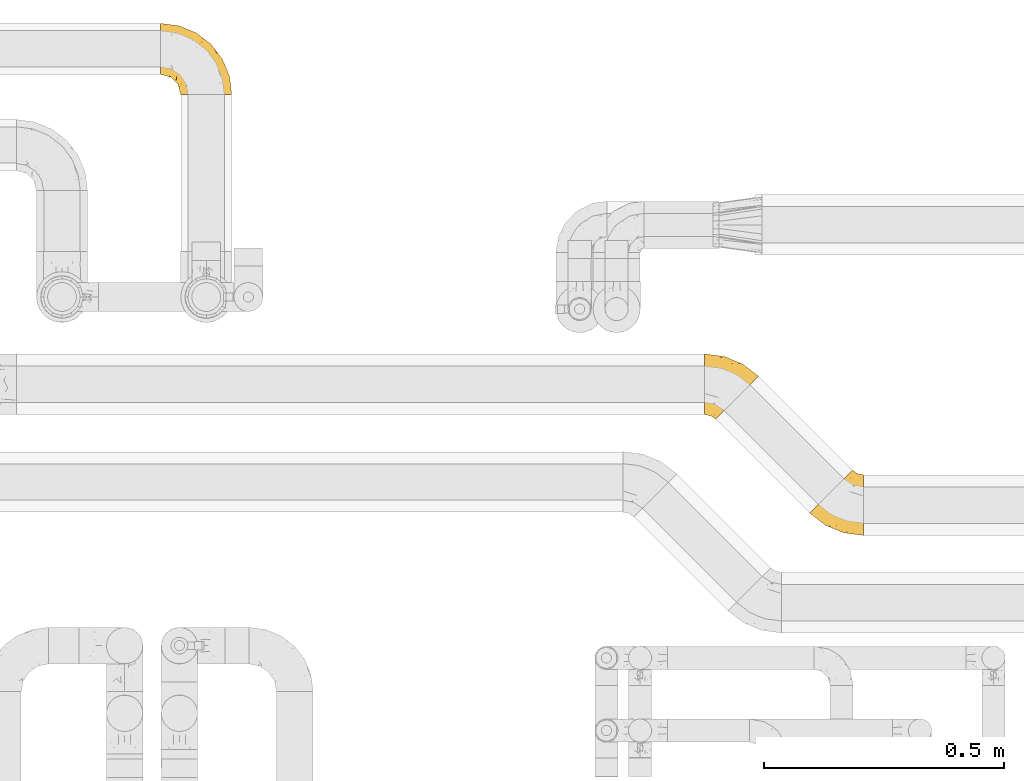
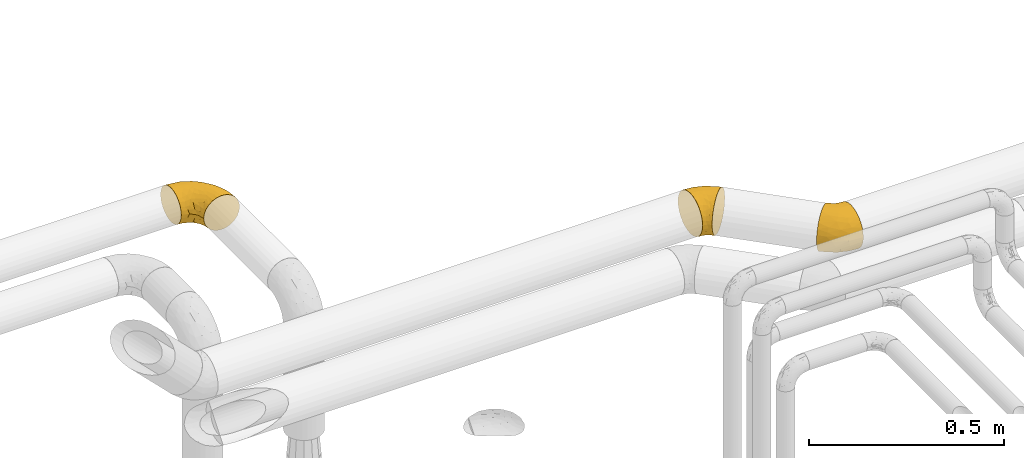
# One storey, part 412 of 827: 3 coverings.
"""IFC2X3 building model written with IfcOpenShell, lengths in millimetres."""

from ifc_helpers import new_model, entity, si_unit, converted_unit, derived_unit, direction, frame, origin, place, context, subcontext, project, spatial, faceted_brep, element, save


model = new_model("IFC2X3")

# Units and contexts
model_context = context("Model", 3, precision=0.01, world=origin(), true_north=direction((6.12303176911189e-17, 1.0)))
body_context = subcontext(model_context, "Body", "Model", "MODEL_VIEW")
ifc_project = project(units=[si_unit("LENGTHUNIT", "METRE", prefix="MILLI"), si_unit("AREAUNIT", "SQUARE_METRE"), si_unit("VOLUMEUNIT", "CUBIC_METRE"), converted_unit("PLANEANGLEUNIT", "DEGREE", entity("IfcRatioMeasure", 0.0174532925199433), si_unit("PLANEANGLEUNIT", "RADIAN"), dimensions=[0, 0, 0, 0, 0, 0, 0]), si_unit("MASSUNIT", "GRAM", prefix="KILO"), derived_unit("MASSDENSITYUNIT", [(si_unit("MASSUNIT", "GRAM", prefix="KILO"), 1), (si_unit("LENGTHUNIT", "METRE"), -3)]), derived_unit("MOMENTOFINERTIAUNIT", [(si_unit("LENGTHUNIT", "METRE"), 4)]), si_unit("TIMEUNIT", "SECOND"), si_unit("FREQUENCYUNIT", "HERTZ"), si_unit("THERMODYNAMICTEMPERATUREUNIT", "DEGREE_CELSIUS"), derived_unit("THERMALTRANSMITTANCEUNIT", [(si_unit("MASSUNIT", "GRAM", prefix="KILO"), 1), (si_unit("THERMODYNAMICTEMPERATUREUNIT", "KELVIN"), -1), (si_unit("TIMEUNIT", "SECOND"), -3)]), derived_unit("VOLUMETRICFLOWRATEUNIT", [(si_unit("LENGTHUNIT", "METRE"), 3), (si_unit("TIMEUNIT", "SECOND"), -1)]), derived_unit("MASSFLOWRATEUNIT", [(si_unit("MASSUNIT", "GRAM", prefix="KILO"), 1), (si_unit("TIMEUNIT", "SECOND"), -1)]), derived_unit("ROTATIONALFREQUENCYUNIT", [(si_unit("TIMEUNIT", "SECOND"), -1)]), si_unit("ELECTRICCURRENTUNIT", "AMPERE"), si_unit("ELECTRICVOLTAGEUNIT", "VOLT"), si_unit("POWERUNIT", "WATT"), si_unit("FORCEUNIT", "NEWTON", prefix="KILO"), si_unit("ILLUMINANCEUNIT", "LUX"), si_unit("LUMINOUSFLUXUNIT", "LUMEN"), si_unit("LUMINOUSINTENSITYUNIT", "CANDELA"), derived_unit("USERDEFINED", [(si_unit("MASSUNIT", "GRAM", prefix="KILO"), -1), (si_unit("LENGTHUNIT", "METRE"), -2), (si_unit("TIMEUNIT", "SECOND"), 3), (si_unit("LUMINOUSFLUXUNIT", "LUMEN"), 1)]), derived_unit("LINEARVELOCITYUNIT", [(si_unit("LENGTHUNIT", "METRE"), 1), (si_unit("TIMEUNIT", "SECOND"), -1)]), si_unit("PRESSUREUNIT", "PASCAL"), derived_unit("USERDEFINED", [(si_unit("LENGTHUNIT", "METRE"), -2), (si_unit("MASSUNIT", "GRAM", prefix="KILO"), 1), (si_unit("TIMEUNIT", "SECOND"), -2)]), derived_unit("LINEARFORCEUNIT", [(si_unit("MASSUNIT", "GRAM", prefix="KILO"), 1), (si_unit("LENGTHUNIT", "METRE"), 1), (si_unit("TIMEUNIT", "SECOND"), -2), (si_unit("LENGTHUNIT", "METRE"), -1)]), derived_unit("PLANARFORCEUNIT", [(si_unit("MASSUNIT", "GRAM", prefix="KILO"), 1), (si_unit("LENGTHUNIT", "METRE"), 1), (si_unit("TIMEUNIT", "SECOND"), -2), (si_unit("LENGTHUNIT", "METRE"), -2)])], contexts=[model_context])

# Site, building, storey
site_placement = place(None, origin())
site = spatial("IfcSite", under=ifc_project, at=site_placement, CompositionType="ELEMENT")
building_placement = place(site_placement, origin())
building = spatial("IfcBuilding", under=site, at=building_placement, CompositionType="ELEMENT")
storey_placement = place(building_placement, frame((0.0, 0.0, 28200.0)))
storey = spatial("IfcBuildingStorey", under=building, at=storey_placement, Name="08", CompositionType="ELEMENT", Elevation=28200.0)

# Coverings
covering_1_placement = place(storey_placement, frame((48061.03, 18493.86, 2935.35)))
element("IfcCovering", 1, at=covering_1_placement, inside=storey, Name=":ADSK_", ObjectType=":ADSK_", PredefinedType="INSULATION", context=body_context, shape_type="Brep", body=[
    faceted_brep([(113.35, 127.7, 64.65), (113.35, 126.11, 78.67), (113.35, 121.45, 92.0), (113.35, 113.94, 103.95), (113.35, 103.96, 113.94), (113.35, 92.0, 121.45), (113.35, 78.68, 126.11), (113.35, 64.65, 127.7), (113.35, 50.62, 126.11), (113.35, 37.29, 121.45), (113.35, 25.34, 113.94), (113.35, 15.35, 103.96), (113.35, 7.84, 92.0), (113.35, 3.18, 78.68), (113.35, 1.6, 64.65), (113.35, 3.18, 50.62), (113.35, 7.84, 37.29), (113.35, 15.35, 25.34), (113.35, 25.33, 15.35), (113.35, 37.29, 7.84), (113.35, 50.61, 3.18), (113.35, 64.65, 1.6), (113.35, 78.67, 3.18), (113.35, 92.0, 7.84), (113.35, 103.95, 15.35), (113.35, 113.94, 25.33), (113.35, 121.45, 37.29), (113.35, 126.11, 50.61), (90.76, 137.05, 64.65), (89.24, 135.53, 48.33), (84.79, 131.08, 33.12), (77.7, 124.0, 20.06), (68.47, 114.76, 10.04), (57.72, 104.01, 3.74), (46.18, 92.47, 1.6), (34.64, 80.93, 3.74), (23.89, 70.18, 10.04), (14.65, 60.95, 20.06), (7.57, 53.86, 33.12), (3.11, 49.41, 48.33), (1.6, 47.89, 64.65), (3.11, 49.41, 80.96), (7.57, 53.86, 96.17), (14.65, 60.95, 109.23), (23.89, 70.18, 119.25), (34.64, 80.93, 125.55), (46.18, 92.47, 127.7), (57.72, 104.01, 125.55), (68.47, 114.76, 119.25), (77.7, 124.0, 109.23), (84.79, 131.08, 96.17), (89.24, 135.53, 80.96), (82.25, 22.45, 108.1), (34.33, 22.77, 64.65), (21.83, 33.18, 80.19), (32.11, 38.64, 102.05), (72.45, 6.98, 64.65), (42.98, 20.62, 81.27), (69.69, 54.22, 124.73), (45.61, 59.86, 122.26), (78.83, 8.74, 84.6), (55.06, 37.39, 113.02), (65.85, 77.37, 127.7), (56.15, 84.82, 127.7), (86.72, 13.12, 97.32), (56.96, 21.15, 96.3), (86.58, 32.48, 117.12), (26.66, 34.19, 90.52), (100.89, 66.29, 127.7), (88.77, 67.88, 127.7), (77.31, 72.63, 127.7), (65.07, 43.92, 119.88), (102.7, 95.22, 120.26), (100.29, 80.66, 125.9), (69.96, 95.96, 125.09), (81.48, 107.27, 117.94), (100.72, 107.42, 112.32), (90.26, 93.57, 122.53), (96.84, 118.48, 102.2), (86.87, 121.19, 105.16), (91.1, 111.65, 111.58), (106.05, 117.49, 99.98), (95.88, 131.99, 74.42), (101.77, 125.2, 87.77), (104.32, 127.93, 75.98), (87.42, 80.56, 126.59), (79.05, 88.58, 125.61), (92.68, 128.43, 90.37), (101.13, 130.13, 64.65), (101.77, 125.19, 41.51), (100.72, 107.41, 16.97), (97.53, 130.44, 52.07), (81.48, 107.27, 11.35), (69.96, 95.96, 4.2), (93.01, 126.18, 35.35), (96.84, 118.48, 27.09), (56.15, 84.82, 1.6), (87.42, 80.56, 2.7), (88.77, 67.88, 1.6), (77.31, 72.63, 1.6), (102.7, 95.22, 9.03), (90.26, 93.56, 6.76), (77.09, 85.62, 2.86), (79.18, 96.8, 6.13), (86.87, 121.19, 24.13), (91.09, 111.65, 17.7), (100.29, 80.66, 3.39), (106.05, 117.49, 29.31), (100.89, 66.29, 1.6), (65.85, 77.37, 1.6), (69.69, 54.22, 4.56), (45.61, 59.86, 7.03), (82.25, 22.44, 21.19), (55.07, 37.39, 16.27), (86.58, 32.48, 12.17), (86.72, 13.12, 31.97), (56.96, 21.15, 33.0), (32.11, 38.63, 27.24), (21.84, 33.18, 49.11), (26.66, 34.19, 38.77), (78.83, 8.73, 44.69), (42.98, 20.62, 48.02), (65.07, 43.91, 9.41)], [[[0, 1, 2, 3, 4, 5, 6, 7, 8, 9, 10, 11, 12, 13, 14, 15, 16, 17, 18, 19, 20, 21, 22, 23, 24, 25, 26, 27]], [[28, 29, 30, 31, 32, 33, 34, 35, 36, 37, 38, 39, 40, 41, 42, 43, 44, 45, 46, 47, 48, 49, 50, 51]], [[52, 11, 10]], [[40, 53, 54]], [[42, 55, 43]], [[53, 56, 57]], [[9, 8, 58]], [[45, 59, 58]], [[56, 13, 60]], [[61, 44, 43]], [[45, 62, 63, 46]], [[62, 45, 58]], [[59, 45, 44]], [[64, 52, 65]], [[55, 61, 43]], [[61, 65, 52]], [[60, 57, 56]], [[60, 65, 57]], [[52, 10, 66]], [[64, 12, 11]], [[64, 60, 12]], [[13, 56, 14]], [[61, 55, 65]], [[67, 55, 42]], [[54, 67, 41]], [[61, 52, 66]], [[66, 10, 9]], [[8, 7, 68, 69]], [[58, 69, 70, 62]], [[58, 8, 69]], [[60, 64, 65]], [[52, 64, 11]], [[58, 59, 71]], [[54, 57, 67]], [[58, 66, 9]], [[60, 13, 12]], [[41, 67, 42]], [[65, 55, 67]], [[65, 67, 57]], [[40, 54, 41]], [[53, 57, 54]], [[44, 61, 59]], [[58, 71, 66]], [[59, 61, 71]], [[61, 66, 71]], [[72, 73, 5]], [[62, 74, 63]], [[48, 75, 49]], [[63, 74, 47]], [[75, 48, 74]], [[72, 76, 77]], [[78, 79, 80]], [[81, 3, 2]], [[82, 28, 51]], [[83, 84, 82]], [[73, 77, 85]], [[86, 62, 70]], [[83, 87, 78]], [[50, 87, 51]], [[86, 75, 74]], [[68, 73, 69]], [[5, 4, 72]], [[73, 6, 5]], [[74, 48, 47]], [[73, 68, 6]], [[80, 77, 76]], [[69, 85, 70]], [[81, 76, 3]], [[88, 84, 0]], [[84, 83, 1]], [[1, 83, 2]], [[3, 76, 4]], [[50, 49, 79]], [[83, 78, 81]], [[80, 76, 78]], [[73, 72, 77]], [[76, 72, 4]], [[85, 86, 70]], [[68, 7, 6]], [[73, 85, 69]], [[86, 85, 77]], [[75, 86, 77]], [[86, 74, 62]], [[47, 46, 63]], [[83, 81, 2]], [[76, 81, 78]], [[75, 79, 49]], [[87, 79, 78]], [[79, 75, 80]], [[77, 80, 75]], [[0, 84, 1]], [[82, 84, 88]], [[28, 82, 88]], [[82, 51, 87]], [[87, 50, 79]], [[82, 87, 83]], [[27, 26, 89]], [[25, 24, 90]], [[88, 91, 28]], [[32, 92, 93]], [[94, 89, 95]], [[94, 29, 91]], [[93, 96, 33]], [[97, 98, 99]], [[24, 23, 100]], [[101, 102, 103]], [[104, 95, 105]], [[93, 33, 32]], [[100, 90, 24]], [[102, 97, 99]], [[91, 27, 89]], [[97, 106, 98]], [[26, 107, 89]], [[93, 92, 103]], [[90, 95, 107]], [[31, 92, 32]], [[31, 30, 104]], [[107, 26, 25]], [[23, 22, 106]], [[101, 97, 102]], [[89, 94, 91]], [[31, 104, 92]], [[98, 106, 108]], [[106, 22, 108]], [[100, 106, 101]], [[101, 92, 105]], [[106, 100, 23]], [[27, 88, 0]], [[90, 100, 101]], [[22, 21, 108]], [[93, 102, 109]], [[106, 97, 101]], [[109, 102, 99]], [[102, 93, 103]], [[96, 93, 109]], [[96, 34, 33]], [[101, 103, 92]], [[90, 107, 25]], [[89, 107, 95]], [[94, 104, 30]], [[95, 90, 105]], [[101, 105, 90]], [[92, 104, 105]], [[104, 94, 95]], [[29, 94, 30]], [[28, 91, 29]], [[27, 91, 88]], [[35, 110, 111]], [[112, 113, 114]], [[35, 34, 96, 109]], [[112, 114, 18]], [[112, 115, 116]], [[117, 113, 116]], [[39, 118, 40]], [[116, 119, 117]], [[120, 121, 116]], [[113, 117, 37]], [[36, 113, 37]], [[38, 117, 119]], [[119, 116, 121]], [[20, 19, 110]], [[110, 109, 99, 98]], [[122, 111, 110]], [[20, 98, 108, 21]], [[37, 117, 38]], [[112, 18, 17]], [[39, 119, 118]], [[116, 113, 112]], [[110, 35, 109]], [[119, 39, 38]], [[114, 19, 18]], [[121, 120, 56]], [[115, 17, 16]], [[15, 14, 56]], [[15, 56, 120]], [[110, 19, 114]], [[115, 120, 116]], [[121, 56, 53]], [[15, 120, 16]], [[115, 112, 17]], [[20, 110, 98]], [[120, 115, 16]], [[35, 111, 36]], [[119, 121, 118]], [[121, 53, 118]], [[40, 118, 53]], [[122, 110, 114]], [[113, 36, 111]], [[114, 113, 122]], [[113, 111, 122]]]),
])
covering_2_placement = place(storey_placement, frame((47842.77, 18735.82, 2935.35)))
element("IfcCovering", 2, at=covering_2_placement, inside=storey, Name=":ADSK_", ObjectType=":ADSK_", PredefinedType="INSULATION", context=body_context, shape_type="Brep", body=[
    faceted_brep([(1.6, 10.95, 64.65), (1.6, 12.53, 78.67), (1.6, 17.2, 92.0), (1.6, 24.71, 103.95), (1.6, 34.69, 113.94), (1.6, 46.64, 121.45), (1.6, 59.97, 126.11), (1.6, 74.0, 127.7), (1.6, 88.03, 126.11), (1.6, 101.36, 121.45), (1.6, 113.31, 113.94), (1.6, 123.3, 103.96), (1.6, 130.81, 92.0), (1.6, 135.47, 78.68), (1.6, 137.05, 64.65), (1.6, 135.47, 50.62), (1.6, 130.81, 37.29), (1.6, 123.3, 25.34), (1.6, 113.32, 15.35), (1.6, 101.36, 7.84), (1.6, 88.04, 3.18), (1.6, 74.0, 1.6), (1.6, 59.97, 3.18), (1.6, 46.65, 7.84), (1.6, 34.69, 15.35), (1.6, 24.71, 25.33), (1.6, 17.2, 37.29), (1.6, 12.53, 50.61), (24.19, 1.6, 64.65), (25.71, 3.11, 48.33), (30.16, 7.57, 33.12), (37.25, 14.65, 20.06), (46.48, 23.89, 10.04), (57.23, 34.64, 3.74), (68.77, 46.18, 1.6), (80.31, 57.72, 3.74), (91.06, 68.47, 10.04), (100.3, 77.7, 20.06), (107.38, 84.79, 33.12), (111.83, 89.24, 48.33), (113.35, 90.76, 64.65), (111.83, 89.24, 80.96), (107.38, 84.79, 96.17), (100.3, 77.7, 109.23), (91.06, 68.47, 119.25), (80.31, 57.72, 125.55), (68.77, 46.18, 127.7), (57.23, 34.64, 125.55), (46.48, 23.89, 119.25), (37.25, 14.65, 109.23), (30.16, 7.57, 96.17), (25.71, 3.11, 80.96), (32.7, 116.2, 108.1), (80.62, 115.88, 64.65), (93.11, 105.47, 80.19), (82.84, 100.01, 102.05), (42.5, 131.67, 64.65), (71.97, 118.02, 81.27), (45.26, 84.43, 124.73), (69.34, 78.79, 122.26), (36.12, 129.91, 84.6), (59.89, 101.26, 113.02), (49.1, 61.28, 127.7), (58.8, 53.83, 127.7), (28.22, 125.53, 97.32), (57.99, 117.49, 96.3), (28.36, 106.16, 117.12), (88.29, 104.46, 90.52), (14.06, 72.36, 127.7), (26.18, 70.77, 127.7), (37.64, 66.02, 127.7), (49.88, 94.73, 119.88), (12.25, 43.42, 120.26), (14.66, 57.99, 125.9), (44.99, 42.69, 125.09), (33.47, 31.37, 117.94), (14.23, 31.23, 112.32), (24.69, 45.08, 122.53), (18.1, 20.17, 102.2), (28.08, 17.46, 105.16), (23.85, 27.0, 111.58), (8.9, 21.15, 99.98), (19.06, 6.66, 74.42), (13.18, 13.45, 87.77), (10.63, 10.72, 75.98), (27.52, 58.08, 126.59), (35.9, 50.06, 125.61), (22.27, 10.21, 90.37), (13.82, 8.52, 64.65), (13.18, 13.45, 41.51), (14.23, 31.24, 16.97), (17.42, 8.21, 52.07), (33.46, 31.38, 11.35), (44.99, 42.69, 4.2), (21.94, 12.47, 35.35), (18.11, 20.17, 27.09), (58.8, 53.83, 1.6), (27.53, 58.09, 2.7), (26.18, 70.77, 1.6), (37.64, 66.02, 1.6), (12.25, 43.43, 9.03), (24.69, 45.08, 6.76), (37.86, 53.03, 2.86), (35.77, 41.85, 6.13), (28.08, 17.46, 24.13), (23.85, 27.0, 17.7), (14.66, 57.99, 3.39), (8.9, 21.16, 29.31), (14.06, 72.36, 1.6), (49.1, 61.28, 1.6), (45.26, 84.43, 4.56), (69.34, 78.79, 7.03), (32.7, 116.21, 21.19), (59.88, 101.26, 16.27), (28.36, 106.17, 12.17), (28.23, 125.53, 31.97), (57.99, 117.5, 33.0), (82.84, 100.01, 27.24), (93.11, 105.47, 49.11), (88.29, 104.46, 38.77), (36.12, 129.91, 44.69), (71.97, 118.03, 48.02), (49.88, 94.73, 9.41)], [[[0, 1, 2, 3, 4, 5, 6, 7, 8, 9, 10, 11, 12, 13, 14, 15, 16, 17, 18, 19, 20, 21, 22, 23, 24, 25, 26, 27]], [[28, 29, 30, 31, 32, 33, 34, 35, 36, 37, 38, 39, 40, 41, 42, 43, 44, 45, 46, 47, 48, 49, 50, 51]], [[52, 11, 10]], [[40, 53, 54]], [[42, 55, 43]], [[53, 56, 57]], [[9, 8, 58]], [[45, 59, 58]], [[56, 13, 60]], [[61, 44, 43]], [[45, 62, 63, 46]], [[62, 45, 58]], [[59, 45, 44]], [[64, 52, 65]], [[55, 61, 43]], [[61, 65, 52]], [[60, 57, 56]], [[60, 65, 57]], [[52, 10, 66]], [[64, 12, 11]], [[64, 60, 12]], [[13, 56, 14]], [[61, 55, 65]], [[67, 55, 42]], [[54, 67, 41]], [[61, 52, 66]], [[66, 10, 9]], [[8, 7, 68, 69]], [[58, 69, 70, 62]], [[58, 8, 69]], [[60, 64, 65]], [[52, 64, 11]], [[58, 59, 71]], [[54, 57, 67]], [[58, 66, 9]], [[60, 13, 12]], [[41, 67, 42]], [[65, 55, 67]], [[65, 67, 57]], [[40, 54, 41]], [[53, 57, 54]], [[44, 61, 59]], [[58, 71, 66]], [[59, 61, 71]], [[61, 66, 71]], [[72, 73, 5]], [[62, 74, 63]], [[48, 75, 49]], [[63, 74, 47]], [[75, 48, 74]], [[72, 76, 77]], [[78, 79, 80]], [[81, 3, 2]], [[82, 28, 51]], [[83, 84, 82]], [[73, 77, 85]], [[86, 62, 70]], [[83, 87, 78]], [[50, 87, 51]], [[86, 75, 74]], [[68, 73, 69]], [[5, 4, 72]], [[73, 6, 5]], [[74, 48, 47]], [[73, 68, 6]], [[80, 77, 76]], [[69, 85, 70]], [[81, 76, 3]], [[88, 84, 0]], [[84, 83, 1]], [[1, 83, 2]], [[3, 76, 4]], [[50, 49, 79]], [[83, 78, 81]], [[80, 76, 78]], [[73, 72, 77]], [[76, 72, 4]], [[85, 86, 70]], [[68, 7, 6]], [[73, 85, 69]], [[86, 85, 77]], [[75, 86, 77]], [[86, 74, 62]], [[47, 46, 63]], [[83, 81, 2]], [[76, 81, 78]], [[75, 79, 49]], [[87, 79, 78]], [[79, 75, 80]], [[77, 80, 75]], [[0, 84, 1]], [[82, 84, 88]], [[28, 82, 88]], [[82, 51, 87]], [[87, 50, 79]], [[82, 87, 83]], [[27, 26, 89]], [[25, 24, 90]], [[88, 91, 28]], [[32, 92, 93]], [[94, 89, 95]], [[94, 29, 91]], [[93, 96, 33]], [[97, 98, 99]], [[24, 23, 100]], [[101, 102, 103]], [[104, 95, 105]], [[93, 33, 32]], [[100, 90, 24]], [[102, 97, 99]], [[91, 27, 89]], [[97, 106, 98]], [[26, 107, 89]], [[93, 92, 103]], [[90, 95, 107]], [[31, 92, 32]], [[31, 30, 104]], [[107, 26, 25]], [[23, 22, 106]], [[101, 97, 102]], [[89, 94, 91]], [[31, 104, 92]], [[98, 106, 108]], [[106, 22, 108]], [[100, 106, 101]], [[101, 92, 105]], [[106, 100, 23]], [[27, 88, 0]], [[90, 100, 101]], [[22, 21, 108]], [[93, 102, 109]], [[106, 97, 101]], [[109, 102, 99]], [[102, 93, 103]], [[96, 93, 109]], [[96, 34, 33]], [[101, 103, 92]], [[90, 107, 25]], [[89, 107, 95]], [[94, 104, 30]], [[95, 90, 105]], [[101, 105, 90]], [[92, 104, 105]], [[104, 94, 95]], [[29, 94, 30]], [[28, 91, 29]], [[27, 91, 88]], [[35, 110, 111]], [[112, 113, 114]], [[35, 34, 96, 109]], [[112, 114, 18]], [[112, 115, 116]], [[117, 113, 116]], [[39, 118, 40]], [[116, 119, 117]], [[120, 121, 116]], [[113, 117, 37]], [[36, 113, 37]], [[38, 117, 119]], [[119, 116, 121]], [[20, 19, 110]], [[110, 109, 99, 98]], [[122, 111, 110]], [[20, 98, 108, 21]], [[37, 117, 38]], [[112, 18, 17]], [[39, 119, 118]], [[116, 113, 112]], [[110, 35, 109]], [[119, 39, 38]], [[114, 19, 18]], [[121, 120, 56]], [[115, 17, 16]], [[15, 14, 56]], [[15, 56, 120]], [[110, 19, 114]], [[115, 120, 116]], [[121, 56, 53]], [[15, 120, 16]], [[115, 112, 17]], [[20, 110, 98]], [[120, 115, 16]], [[35, 111, 36]], [[119, 121, 118]], [[121, 53, 118]], [[40, 118, 53]], [[122, 110, 114]], [[113, 36, 111]], [[114, 113, 122]], [[113, 111, 122]]]),
])
covering_3_placement = place(storey_placement, frame((46711.22, 19410.64, 2945.35)))
element("IfcCovering", 3, at=covering_3_placement, inside=storey, Name=":ADSK_", ObjectType=":ADSK_", PredefinedType="INSULATION", context=body_context, shape_type="Brep", body=[
    faceted_brep([(1.6, 148.32, 66.44), (1.6, 149.65, 54.65), (1.6, 148.31, 42.84), (1.6, 144.39, 31.62), (1.6, 138.06, 21.56), (1.6, 129.66, 13.16), (1.6, 119.6, 6.84), (1.6, 108.39, 2.92), (1.6, 96.6, 1.6), (1.6, 84.79, 2.93), (1.6, 73.57, 6.85), (1.6, 63.51, 13.18), (1.6, 55.11, 21.58), (1.6, 48.79, 31.64), (1.6, 44.87, 42.85), (1.6, 43.55, 54.65), (1.6, 44.88, 66.46), (1.6, 48.8, 77.67), (1.6, 55.13, 87.73), (1.6, 63.53, 96.13), (1.6, 73.59, 102.45), (1.6, 84.8, 106.37), (1.6, 96.6, 107.7), (1.6, 108.41, 106.36), (1.6, 119.62, 102.44), (1.6, 129.68, 96.11), (1.6, 138.08, 87.71), (1.6, 144.4, 77.65), (45.35, 1.6, 40.91), (50.65, 1.6, 28.12), (59.08, 1.6, 17.13), (70.07, 1.6, 8.7), (82.86, 1.6, 3.4), (96.6, 1.6, 1.6), (110.33, 1.6, 3.4), (123.12, 1.6, 8.7), (134.11, 1.6, 17.13), (142.54, 1.6, 28.12), (147.84, 1.6, 40.91), (149.65, 1.6, 54.65), (147.84, 1.6, 68.38), (142.54, 1.6, 81.17), (134.11, 1.6, 92.16), (123.12, 1.6, 100.59), (110.33, 1.6, 105.89), (96.6, 1.6, 107.7), (82.86, 1.6, 105.89), (70.07, 1.6, 100.59), (59.08, 1.6, 92.16), (50.65, 1.6, 81.17), (45.35, 1.6, 68.38), (43.55, 1.6, 54.65), (137.19, 27.97, 85.53), (141.79, 37.09, 73.42), (128.89, 58.27, 83.77), (146.54, 27.13, 64.22), (144.6, 39.91, 54.65), (69.77, 109.11, 96.72), (94.41, 94.41, 93.36), (87.22, 110.94, 84.47), (117.2, 89.69, 71.37), (129.81, 75.62, 54.65), (106.28, 106.28, 54.65), (101.45, 60.12, 103.47), (115.81, 41.41, 100.91), (109.14, 63.22, 99.1), (107.65, 32.05, 105.43), (93.36, 52.13, 106.79), (59.44, 123.27, 89.81), (63.23, 129.32, 79.59), (35.59, 138.3, 81.29), (132.3, 62.95, 74.01), (138.41, 55.89, 64.14), (126.28, 37.4, 94.75), (39.91, 144.6, 54.65), (37.44, 142.66, 70.74), (90.35, 117.85, 68.3), (65.0, 134.01, 66.05), (85.4, 89.25, 100.73), (26.66, 103.34, 106.78), (29.88, 113.52, 103.6), (78.45, 57.43, 107.7), (85.2, 44.19, 107.7), (91.95, 30.95, 107.7), (77.98, 77.98, 106.07), (29.55, 132.66, 90.59), (41.42, 121.52, 97.43), (111.13, 86.93, 84.51), (114.67, 68.4, 93.3), (57.43, 78.45, 107.7), (67.94, 67.94, 107.7), (14.64, 94.53, 107.7), (30.95, 91.95, 107.7), (52.13, 93.36, 106.79), (44.19, 85.2, 107.7), (60.12, 101.45, 103.47), (75.62, 129.81, 54.65), (94.27, 16.27, 107.7), (24.59, 42.46, 76.99), (34.69, 40.4, 84.28), (31.15, 49.71, 91.11), (75.18, 39.4, 106.26), (67.55, 31.26, 102.6), (79.36, 27.7, 106.08), (84.32, 16.7, 106.56), (40.81, 70.67, 105.36), (29.93, 81.69, 106.74), (70.24, 16.68, 101.59), (37.93, 22.57, 54.65), (40.15, 14.26, 54.65), (42.1, 17.68, 67.71), (55.38, 19.58, 91.36), (52.17, 33.49, 94.33), (44.32, 33.01, 87.1), (19.85, 40.69, 65.84), (14.26, 40.15, 54.65), (22.57, 37.93, 54.65), (34.17, 31.04, 68.92), (54.85, 45.29, 100.82), (44.63, 23.55, 79.83), (47.52, 11.36, 77.13), (59.1, 59.1, 105.9), (44.11, 57.42, 101.53), (53.21, 68.96, 106.72), (62.86, 20.38, 97.75), (20.58, 72.46, 103.08), (15.79, 83.66, 106.39), (27.67, 60.66, 98.1), (13.49, 61.01, 95.02), (18.04, 51.85, 86.9), (12.44, 46.07, 74.42), (30.25, 30.25, 54.65), (66.71, 46.65, 105.28), (42.52, 43.0, 92.87), (55.38, 19.58, 17.93), (20.57, 72.44, 6.22), (42.11, 17.67, 41.58), (57.43, 78.45, 1.6), (53.22, 68.97, 2.57), (40.81, 70.65, 3.94), (19.85, 40.69, 43.46), (24.58, 42.45, 32.32), (34.16, 31.04, 40.38), (42.5, 42.99, 16.44), (54.93, 45.18, 8.47), (52.13, 33.46, 15.01), (27.66, 60.64, 11.21), (44.12, 57.37, 7.78), (78.45, 57.43, 1.6), (85.2, 44.19, 1.6), (75.17, 39.35, 3.04), (94.27, 16.27, 1.6), (84.32, 16.7, 2.73), (30.95, 91.95, 1.6), (44.19, 85.2, 1.6), (29.98, 81.68, 2.55), (66.78, 46.68, 3.98), (67.55, 31.26, 6.69), (70.24, 16.68, 7.7), (79.36, 27.7, 3.21), (13.48, 60.99, 14.28), (18.03, 51.84, 22.42), (34.66, 40.41, 25.02), (31.14, 49.72, 18.18), (12.43, 46.06, 34.89), (14.64, 94.53, 1.6), (47.52, 11.35, 32.17), (44.28, 33.02, 22.23), (15.8, 83.65, 2.91), (62.86, 20.38, 11.54), (67.94, 67.94, 1.6), (44.64, 23.53, 29.46), (59.12, 59.12, 3.38), (91.95, 30.95, 1.6), (128.89, 58.27, 25.52), (137.19, 27.97, 23.76), (126.28, 37.4, 14.54), (115.81, 41.41, 8.38), (146.53, 27.21, 45.07), (141.79, 37.09, 35.87), (139.45, 53.2, 45.14), (93.36, 52.13, 2.5), (26.67, 103.34, 2.51), (29.87, 113.5, 5.68), (60.12, 101.45, 5.82), (94.41, 94.41, 15.93), (69.76, 109.08, 12.54), (87.19, 110.95, 24.81), (52.13, 93.36, 2.5), (77.98, 77.98, 3.22), (107.65, 32.05, 3.86), (131.74, 64.63, 35.85), (59.44, 123.25, 19.47), (29.54, 132.65, 18.68), (63.2, 129.32, 29.68), (27.9, 139.96, 27.95), (90.35, 117.85, 40.99), (117.2, 89.69, 37.92), (41.39, 121.51, 11.85), (109.14, 63.23, 10.19), (85.46, 89.17, 8.55), (37.43, 142.66, 38.53), (114.67, 68.4, 15.99), (111.12, 86.94, 24.79), (101.45, 60.12, 5.82), (65.16, 133.2, 40.56)], [[[0, 1, 2, 3, 4, 5, 6, 7, 8, 9, 10, 11, 12, 13, 14, 15, 16, 17, 18, 19, 20, 21, 22, 23, 24, 25, 26, 27]], [[28, 29, 30, 31, 32, 33, 34, 35, 36, 37, 38, 39, 40, 41, 42, 43, 44, 45, 46, 47, 48, 49, 50, 51]], [[52, 53, 54]], [[55, 39, 56]], [[57, 58, 59]], [[60, 61, 62]], [[63, 64, 65]], [[66, 63, 67]], [[68, 69, 70]], [[53, 71, 54]], [[41, 40, 53]], [[53, 72, 71]], [[73, 42, 52]], [[42, 41, 52]], [[74, 0, 75]], [[69, 76, 77]], [[43, 73, 64]], [[45, 44, 66]], [[57, 78, 58]], [[23, 79, 80]], [[67, 81, 82, 83]], [[67, 84, 81]], [[24, 23, 80]], [[25, 85, 26]], [[86, 85, 25]], [[42, 73, 43]], [[0, 27, 75]], [[25, 24, 86]], [[70, 26, 85]], [[0, 74, 1]], [[68, 85, 86]], [[66, 64, 63]], [[60, 59, 87]], [[54, 87, 88]], [[76, 60, 62]], [[84, 89, 90, 81]], [[79, 22, 91, 92]], [[77, 74, 75]], [[93, 92, 94, 89]], [[80, 86, 24]], [[40, 55, 53]], [[76, 59, 60]], [[93, 84, 95]], [[76, 62, 96]], [[55, 72, 53]], [[70, 27, 26]], [[75, 70, 69]], [[78, 84, 63]], [[93, 79, 92]], [[95, 86, 80]], [[77, 76, 96]], [[59, 69, 68]], [[57, 68, 86]], [[68, 57, 59]], [[59, 58, 87]], [[76, 69, 59]], [[88, 87, 58]], [[87, 54, 71]], [[86, 95, 57]], [[78, 57, 95]], [[84, 78, 95]], [[78, 63, 65]], [[58, 78, 65]], [[54, 88, 73]], [[84, 93, 89]], [[79, 95, 80]], [[79, 93, 95]], [[22, 79, 23]], [[66, 83, 97, 45]], [[84, 67, 63]], [[83, 66, 67]], [[64, 44, 43]], [[64, 66, 44]], [[65, 73, 88]], [[53, 52, 41]], [[73, 52, 54]], [[73, 65, 64]], [[65, 88, 58]], [[39, 55, 40]], [[72, 55, 56]], [[56, 61, 72]], [[60, 72, 61]], [[72, 60, 71]], [[87, 71, 60]], [[27, 70, 75]], [[68, 70, 85]], [[74, 77, 96]], [[69, 77, 75]], [[98, 99, 100]], [[46, 45, 97]], [[101, 102, 103]], [[103, 104, 83]], [[105, 94, 106]], [[107, 103, 102]], [[108, 109, 51, 110]], [[111, 112, 113]], [[114, 115, 116]], [[47, 104, 107]], [[110, 117, 108]], [[49, 48, 111]], [[102, 118, 112]], [[119, 120, 111]], [[50, 49, 120]], [[121, 122, 118]], [[105, 123, 89]], [[124, 48, 107]], [[20, 19, 125]], [[121, 81, 90]], [[117, 119, 99]], [[21, 20, 126]], [[22, 21, 91]], [[105, 125, 127]], [[110, 51, 50]], [[19, 128, 125]], [[16, 15, 115]], [[129, 98, 100]], [[126, 91, 21]], [[128, 129, 127]], [[122, 123, 105]], [[114, 117, 98]], [[17, 16, 130]], [[18, 128, 19]], [[129, 18, 17]], [[125, 106, 126]], [[115, 114, 16]], [[130, 129, 17]], [[114, 98, 130]], [[117, 116, 131, 108]], [[99, 119, 113]], [[122, 121, 123]], [[92, 126, 106]], [[105, 127, 122]], [[132, 121, 118]], [[114, 130, 16]], [[129, 130, 98]], [[50, 120, 110]], [[129, 128, 18]], [[125, 128, 127]], [[125, 126, 20]], [[91, 126, 92]], [[105, 89, 94]], [[105, 106, 125]], [[94, 92, 106]], [[100, 122, 127]], [[118, 122, 133]], [[112, 118, 133]], [[132, 118, 102]], [[132, 102, 101]], [[81, 121, 132]], [[82, 103, 83]], [[132, 101, 81]], [[104, 47, 46]], [[124, 107, 102]], [[48, 47, 107]], [[113, 112, 133]], [[112, 111, 124]], [[99, 113, 133]], [[111, 113, 119]], [[99, 133, 100]], [[117, 99, 98]], [[122, 100, 133]], [[127, 129, 100]], [[103, 82, 101]], [[81, 101, 82]], [[112, 124, 102]], [[48, 124, 111]], [[104, 103, 107]], [[46, 97, 104]], [[111, 120, 49]], [[83, 104, 97]], [[110, 120, 119]], [[117, 110, 119]], [[116, 117, 114]], [[89, 123, 90]], [[90, 123, 121]], [[30, 29, 134]], [[11, 10, 135]], [[51, 109, 108, 136]], [[137, 138, 139]], [[140, 141, 142]], [[143, 144, 145]], [[146, 139, 147]], [[148, 149, 150]], [[151, 32, 152]], [[153, 154, 155]], [[156, 150, 157]], [[158, 157, 159]], [[108, 142, 136]], [[31, 158, 152]], [[160, 161, 12]], [[162, 163, 143]], [[140, 142, 116]], [[142, 141, 162]], [[14, 164, 140]], [[14, 140, 115]], [[9, 8, 165]], [[160, 12, 11]], [[141, 164, 161]], [[13, 12, 161]], [[14, 115, 15]], [[28, 166, 29]], [[135, 139, 146]], [[141, 163, 162]], [[135, 146, 160]], [[143, 167, 162]], [[29, 166, 134]], [[116, 142, 108, 131]], [[165, 153, 168]], [[10, 9, 168]], [[168, 135, 10]], [[138, 147, 139]], [[158, 169, 157]], [[14, 13, 164]], [[116, 115, 140]], [[145, 167, 143]], [[135, 160, 11]], [[168, 153, 155]], [[138, 137, 170]], [[157, 144, 156]], [[147, 144, 143]], [[161, 164, 13]], [[140, 164, 141]], [[142, 171, 136]], [[136, 171, 166]], [[161, 160, 146]], [[165, 168, 9]], [[155, 139, 135]], [[139, 154, 137]], [[168, 155, 135]], [[139, 155, 154]], [[144, 147, 172]], [[163, 147, 143]], [[156, 144, 172]], [[157, 169, 145]], [[172, 148, 156]], [[173, 159, 149]], [[159, 157, 150]], [[152, 159, 173]], [[159, 152, 158]], [[31, 30, 158]], [[169, 30, 134]], [[157, 145, 144]], [[167, 134, 171]], [[134, 167, 145]], [[171, 142, 162]], [[162, 167, 171]], [[163, 141, 161]], [[161, 146, 163]], [[147, 163, 146]], [[148, 150, 156]], [[149, 159, 150]], [[30, 169, 158]], [[145, 169, 134]], [[151, 33, 32]], [[31, 152, 32]], [[152, 173, 151]], [[28, 51, 136]], [[134, 166, 171]], [[28, 136, 166]], [[138, 170, 172]], [[147, 138, 172]], [[148, 172, 170]], [[174, 175, 176]], [[35, 34, 177]], [[178, 179, 180]], [[181, 173, 149, 148]], [[182, 183, 184]], [[185, 186, 187]], [[188, 189, 137]], [[190, 33, 151, 173]], [[191, 179, 174]], [[34, 190, 177]], [[39, 38, 178]], [[192, 193, 194]], [[4, 3, 195]], [[175, 179, 37]], [[38, 37, 179]], [[35, 176, 36]], [[196, 62, 197]], [[181, 190, 173]], [[37, 36, 175]], [[183, 6, 198]], [[189, 148, 170, 137]], [[185, 199, 200]], [[3, 2, 201]], [[202, 185, 203]], [[8, 7, 182]], [[200, 184, 186]], [[183, 7, 6]], [[181, 189, 204]], [[200, 189, 184]], [[5, 198, 6]], [[187, 203, 185]], [[195, 3, 201]], [[205, 196, 194]], [[62, 61, 197]], [[186, 198, 192]], [[180, 179, 191]], [[2, 1, 74]], [[198, 193, 192]], [[193, 5, 4]], [[194, 193, 195]], [[2, 74, 201]], [[5, 193, 198]], [[205, 74, 96]], [[188, 137, 154, 153]], [[62, 196, 96]], [[56, 178, 180]], [[198, 184, 183]], [[184, 188, 182]], [[203, 197, 191]], [[205, 194, 201]], [[187, 192, 194]], [[192, 187, 186]], [[194, 196, 187]], [[197, 187, 196]], [[197, 203, 187]], [[202, 174, 176]], [[200, 186, 185]], [[184, 198, 186]], [[199, 185, 202]], [[189, 200, 204]], [[174, 202, 203]], [[176, 177, 199]], [[189, 181, 148]], [[190, 181, 204]], [[190, 204, 177]], [[190, 34, 33]], [[188, 153, 182]], [[189, 188, 184]], [[182, 153, 165, 8]], [[183, 182, 7]], [[199, 177, 204]], [[35, 177, 176]], [[176, 175, 36]], [[179, 175, 174]], [[200, 199, 204]], [[176, 199, 202]], [[203, 191, 174]], [[180, 197, 61]], [[197, 180, 191]], [[61, 56, 180]], [[39, 178, 56]], [[38, 179, 178]], [[194, 195, 201]], [[4, 195, 193]], [[74, 205, 201]], [[96, 196, 205]]]),
])

save(model, "model.ifc")
